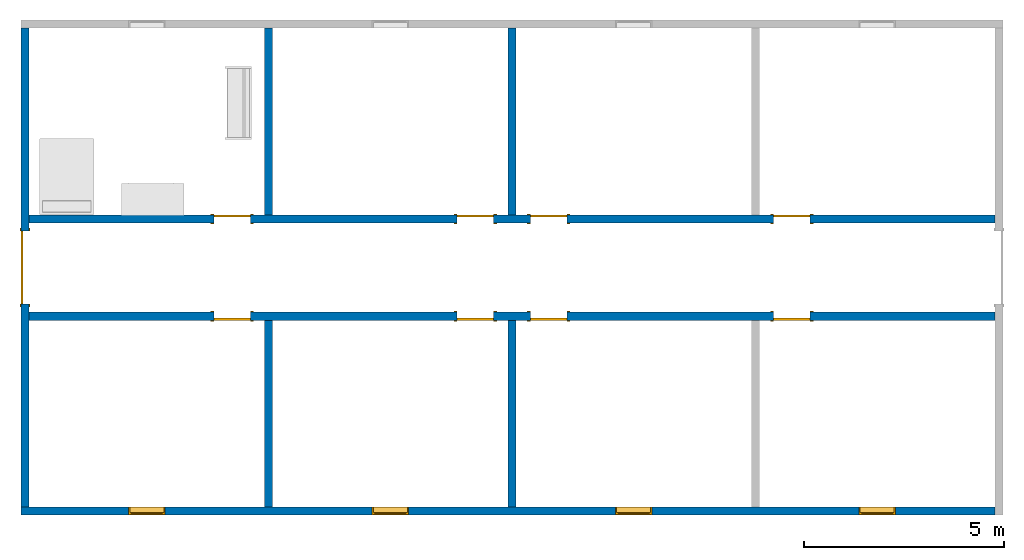
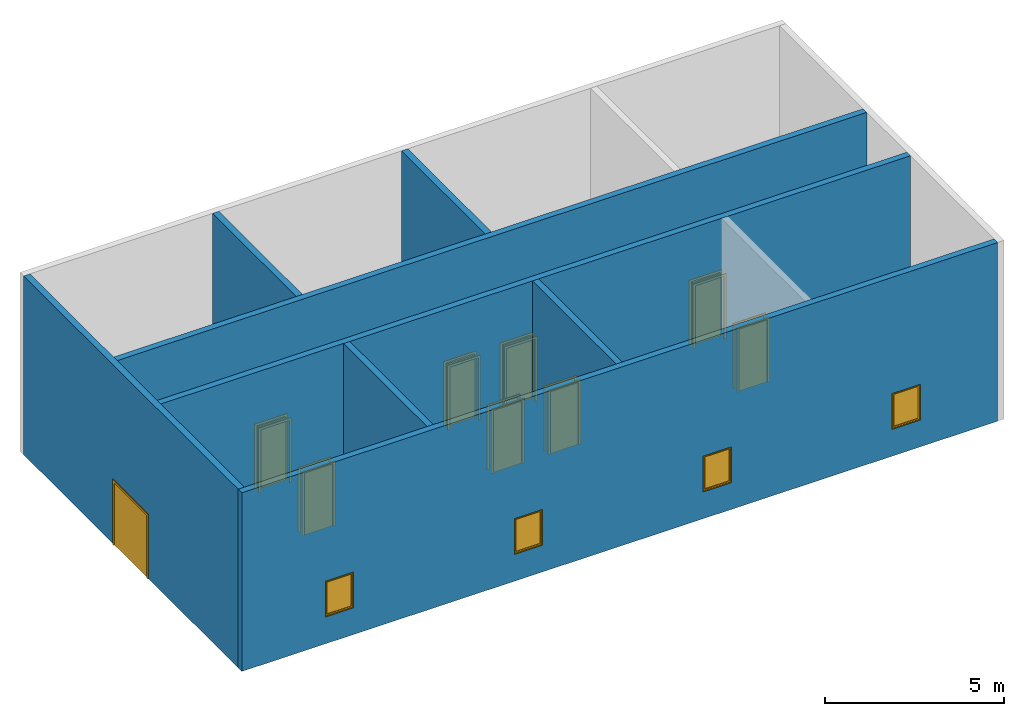
# One storey, part 1 of 4: 9 doors, 8 walls, 4 windows, 13 openings.
"""IFC2X3 building model written with IfcOpenShell, lengths in feet."""

from ifc_helpers import new_model, entity, si_unit, converted_unit, derived_unit, direction, frame, frame_2d, origin, place, context, subcontext, project, spatial, polyline, rectangle, outline, extrude, source, transform, mapped, material, material_list, layer, layer_set, layer_usage, type_object, type_shapes, element, fill, save


model = new_model("IFC2X3")

# Units and contexts
model_context = context("Model", 3, precision=0.0001, world=origin(), true_north=direction((6.123031769111886e-17, 1.0)))
body_context = subcontext(model_context, "Body", "Model", "MODEL_VIEW")
ifc_project = project(units=[converted_unit("LENGTHUNIT", "FOOT", entity("IfcRatioMeasure", 0.3048), si_unit("LENGTHUNIT", "METRE"), dimensions=[1, 0, 0, 0, 0, 0, 0]), converted_unit("AREAUNIT", "SQUARE FOOT", entity("IfcRatioMeasure", 0.09290304), si_unit("AREAUNIT", "SQUARE_METRE"), dimensions=[2, 0, 0, 0, 0, 0, 0]), converted_unit("VOLUMEUNIT", "CUBIC FOOT", entity("IfcRatioMeasure", 0.028316846592000004), si_unit("VOLUMEUNIT", "CUBIC_METRE"), dimensions=[3, 0, 0, 0, 0, 0, 0]), converted_unit("PLANEANGLEUNIT", "DEGREE", entity("IfcRatioMeasure", 0.017453292519943278), si_unit("PLANEANGLEUNIT", "RADIAN"), dimensions=[0, 0, 0, 0, 0, 0, 0]), si_unit("MASSUNIT", "GRAM", prefix="KILO"), derived_unit("MASSDENSITYUNIT", [(si_unit("MASSUNIT", "GRAM", prefix="KILO"), 1), (si_unit("LENGTHUNIT", "METRE"), -3)]), derived_unit("MOMENTOFINERTIAUNIT", [(si_unit("LENGTHUNIT", "METRE"), 4)]), si_unit("TIMEUNIT", "SECOND"), si_unit("FREQUENCYUNIT", "HERTZ"), si_unit("THERMODYNAMICTEMPERATUREUNIT", "DEGREE_CELSIUS"), derived_unit("THERMALTRANSMITTANCEUNIT", [(si_unit("MASSUNIT", "GRAM", prefix="KILO"), 1), (si_unit("THERMODYNAMICTEMPERATUREUNIT", "KELVIN"), -1), (si_unit("TIMEUNIT", "SECOND"), -3)]), derived_unit("VOLUMETRICFLOWRATEUNIT", [(si_unit("LENGTHUNIT", "METRE"), 3), (si_unit("TIMEUNIT", "SECOND"), -1)]), derived_unit("MASSFLOWRATEUNIT", [(si_unit("MASSUNIT", "GRAM", prefix="KILO"), 1), (si_unit("TIMEUNIT", "SECOND"), -1)]), derived_unit("ROTATIONALFREQUENCYUNIT", [(si_unit("TIMEUNIT", "SECOND"), -1)]), si_unit("ELECTRICCURRENTUNIT", "AMPERE"), si_unit("ELECTRICVOLTAGEUNIT", "VOLT"), si_unit("POWERUNIT", "WATT"), si_unit("FORCEUNIT", "NEWTON"), si_unit("ILLUMINANCEUNIT", "LUX"), si_unit("LUMINOUSFLUXUNIT", "LUMEN"), si_unit("LUMINOUSINTENSITYUNIT", "CANDELA"), derived_unit("USERDEFINED", [(si_unit("MASSUNIT", "GRAM", prefix="KILO"), -1), (si_unit("LENGTHUNIT", "METRE"), -2), (si_unit("TIMEUNIT", "SECOND"), 3), (si_unit("LUMINOUSFLUXUNIT", "LUMEN"), 1)]), derived_unit("SOUNDPOWERUNIT", [(si_unit("MASSUNIT", "GRAM", prefix="KILO"), 1), (si_unit("LENGTHUNIT", "METRE"), 2), (si_unit("TIMEUNIT", "SECOND"), -3)]), derived_unit("SOUNDPRESSUREUNIT", [(si_unit("MASSUNIT", "GRAM", prefix="KILO"), 1), (si_unit("LENGTHUNIT", "METRE"), -1), (si_unit("TIMEUNIT", "SECOND"), -2)]), derived_unit("LINEARVELOCITYUNIT", [(si_unit("LENGTHUNIT", "METRE"), 1), (si_unit("TIMEUNIT", "SECOND"), -1)]), si_unit("PRESSUREUNIT", "PASCAL"), derived_unit("USERDEFINED", [(si_unit("LENGTHUNIT", "METRE"), -2), (si_unit("MASSUNIT", "GRAM", prefix="KILO"), 1), (si_unit("TIMEUNIT", "SECOND"), -2)]), derived_unit("LINEARFORCEUNIT", [(si_unit("MASSUNIT", "GRAM", prefix="KILO"), 1), (si_unit("LENGTHUNIT", "METRE"), 1), (si_unit("TIMEUNIT", "SECOND"), -2), (si_unit("LENGTHUNIT", "METRE"), -1)]), derived_unit("PLANARFORCEUNIT", [(si_unit("MASSUNIT", "GRAM", prefix="KILO"), 1), (si_unit("LENGTHUNIT", "METRE"), 1), (si_unit("TIMEUNIT", "SECOND"), -2), (si_unit("LENGTHUNIT", "METRE"), -2)])], contexts=[model_context])

# Site, building, storey
site_placement = place(None, origin())
site = spatial("IfcSite", under=ifc_project, at=site_placement, CompositionType="ELEMENT")
building_placement = place(site_placement, origin())
building = spatial("IfcBuilding", under=site, at=building_placement, CompositionType="ELEMENT")
storey_placement = place(building_placement, origin())
storey = spatial("IfcBuildingStorey", under=building, at=storey_placement, Name="Level 1", CompositionType="ELEMENT", Elevation=0.0)

# Wall, openings, windows
ifc_material_1 = material(Name="Default Wall")
ifc_layer = layer(ifc_material_1, 0.6666666666666666)
ifc_layer_set = layer_set([ifc_layer])
ifc_layer_usage_1 = layer_usage(ifc_layer_set, "AXIS2", "NEGATIVE", 0.3333333333333333)
wall_type = type_object("IfcWallType", PredefinedType="STANDARD", material=ifc_layer_set)
wall_1_placement = place(storey_placement, frame((40.57714681396368, -10.741261883943183, 0.0), z_axis=(0.0, 0.0, 1.0), x_axis=(-1.0, 0.0, 0.0)))
wall_1 = element("IfcWallStandardCase", 1, at=wall_1_placement, inside=storey, type_object=wall_type, material=ifc_layer_usage_1, context=body_context, shape_type="SweptSolid", body=[
    extrude(rectangle(XDim=80.00000000000001, YDim=0.6666666666666661, at=frame_2d((40.000000000000014, -7.216449660063518e-16), x_axis=(-1.0, 0.0))), origin(), (0.0, 0.0, 1.0), 20.0),
])
opening_1_placement = place(wall_1_placement, frame((68.1666666666667, -0.33333333333355597, 3.0)))
opening_1 = element("IfcOpeningElement", 2, at=opening_1_placement, cuts=wall_1, ObjectType="Opening", context=body_context, shape_type="SweptSolid", body=[
    extrude(rectangle(XDim=4.0, YDim=2.9999999999999987, at=frame_2d((2.0, 1.5000000000000007), x_axis=(-1.0, 0.0))), frame((0.0, 0.0, 0.0), z_axis=(0.0, 1.0, 0.0), x_axis=(0.0, 0.0, 1.0)), (0.0, 0.0, 1.0), 0.6666666666666666),
])
opening_2_placement = place(wall_1_placement, frame((48.16666666666669, -0.333333333333492, 3.0)))
opening_2 = element("IfcOpeningElement", 3, at=opening_2_placement, cuts=wall_1, ObjectType="Opening", context=body_context, shape_type="SweptSolid", body=[
    extrude(rectangle(XDim=4.0, YDim=2.9999999999999987, at=frame_2d((2.0, 1.5000000000000007), x_axis=(-1.0, 0.0))), frame((0.0, 0.0, 0.0), z_axis=(0.0, 1.0, 0.0), x_axis=(0.0, 0.0, 1.0)), (0.0, 0.0, 1.0), 0.6666666666666666),
])
opening_3_placement = place(wall_1_placement, frame((28.166666666666742, -0.3333333333334263, 3.0)))
opening_3 = element("IfcOpeningElement", 4, at=opening_3_placement, cuts=wall_1, ObjectType="Opening", context=body_context, shape_type="SweptSolid", body=[
    extrude(rectangle(XDim=4.0, YDim=2.9999999999999987, at=frame_2d((2.0, 1.5000000000000007), x_axis=(-1.0, 0.0))), frame((0.0, 0.0, 0.0), z_axis=(0.0, 1.0, 0.0), x_axis=(0.0, 0.0, 1.0)), (0.0, 0.0, 1.0), 0.6666666666666666),
])
opening_4_placement = place(wall_1_placement, frame((8.166666666666728, -0.33333333333336235, 3.0)))
opening_4 = element("IfcOpeningElement", 5, at=opening_4_placement, cuts=wall_1, ObjectType="Opening", context=body_context, shape_type="SweptSolid", body=[
    extrude(rectangle(XDim=4.0, YDim=2.9999999999999987, at=frame_2d((2.0, 1.5000000000000042), x_axis=(-1.0, 0.0))), frame((0.0, 0.0, 0.0), z_axis=(0.0, 1.0, 0.0), x_axis=(0.0, 0.0, 1.0)), (0.0, 0.0, 1.0), 0.6666666666666666),
])
ifc_material_2 = material(Name="Glass")
ifc_material_3 = material(Name="Sash")
ifc_material_list_1 = material_list([ifc_material_2, ifc_material_3, ifc_material_3, ifc_material_3])
ifc_material_list_2 = material_list([ifc_material_2, ifc_material_3, ifc_material_3, ifc_material_3])
window_style = type_object("IfcWindowStyle", ConstructionType="NOTDEFINED", OperationType="NOTDEFINED", ParameterTakesPrecedence=False, Sizeable=False, material=ifc_material_list_2)
shared_shape_1 = source(origin(), body_context, "Body", "SweptSolid", [
    extrude(rectangle(XDim=2.5833333333333313, YDim=0.04166666666666666, at=frame_2d((0.0, -1.3877787807814457e-17), x_axis=(1.0, 0.0))), frame((1.7500000000000173, 0.53125, 0.2083333333333215)), (0.0, 0.0, 1.0), 3.5833333333333393),
    extrude(outline(polyline([(-1.4374999999999971, -1.9375000000000053), (1.4374999999999971, -1.9375000000000053), (1.4374999999999971, 1.9375000000000053), (-1.4374999999999971, 1.9375000000000053), (-1.4374999999999971, -1.9375000000000053)]), holes=[polyline([(-1.291666666666665, -1.7916666666666696), (-1.291666666666665, 1.7916666666666696), (1.2916666666666663, 1.7916666666666696), (1.2916666666666663, -1.7916666666666696), (-1.291666666666665, -1.7916666666666696)])]), frame((1.750000000000018, 0.6041666666666666, 2.0), z_axis=(0.0, -1.0, 0.0), x_axis=(-1.0, 0.0, 0.0)), (0.0, 0.0, 1.0), 0.14583333333333331),
    extrude(outline(polyline([(-1.499999999999997, -2.0), (1.499999999999997, -2.0), (1.499999999999997, 2.0), (-1.499999999999997, 2.0), (-1.499999999999997, -2.0)]), holes=[polyline([(-1.3958333333333353, -1.8958333333333277), (-1.3958333333333353, 1.8958333333333508), (1.3958333333333293, 1.8958333333333508), (1.3958333333333293, -1.8958333333333277), (-1.3958333333333353, -1.8958333333333277)])]), frame((1.7500000000000149, 0.4583333333333333, 2.0), z_axis=(0.0, -1.0, 0.0), x_axis=(-1.0, 0.0, 0.0)), (0.0, 0.0, 1.0), 0.4583333333333333),
    extrude(outline(polyline([(-2.0, -1.5000000000000002), (2.0, -1.5000000000000002), (2.0, 1.5000000000000002), (-2.0, 1.5000000000000002), (-2.0, -1.5000000000000002)]), holes=[polyline([(-1.9374999999999973, -1.4374999999999953), (-1.9374999999999973, 1.4375000000000016), (1.9375000000000115, 1.4375000000000016), (1.9375000000000115, -1.4374999999999953), (-1.9374999999999973, -1.4374999999999953)])]), frame((1.7500000000000149, 0.6666666666666666, 2.0), z_axis=(0.0, -1.0, 0.0), x_axis=(0.0, 0.0, -1.0)), (0.0, 0.0, 1.0), 0.20833333333333331),
])
type_shapes(window_style, [shared_shape_1])
window_1_placement = place(opening_1_placement, frame((-0.25000000000002487, 0.0, 0.0)))
window_1 = element("IfcWindow", 6, at=window_1_placement, inside=storey, type_object=window_style, material=ifc_material_list_1, OverallHeight=4.0, OverallWidth=3.0, context=body_context, shape_type="MappedRepresentation", body=[
    mapped(shared_shape_1, transform((0.0, 0.0, 0.0), scale=1.0)),
])
fill(opening_1, window_1)
ifc_material_list_3 = material_list([ifc_material_2, ifc_material_3])
window_2_placement = place(opening_2_placement, frame((-0.2500000000000169, 0.0, 0.0)))
window_2 = element("IfcWindow", 7, at=window_2_placement, inside=storey, type_object=window_style, material=ifc_material_list_3, OverallHeight=4.0, OverallWidth=2.999999999999999, context=body_context, shape_type="MappedRepresentation", body=[
    mapped(shared_shape_1, transform((0.0, 0.0, 0.0), scale=1.0)),
])
fill(opening_2, window_2)
ifc_material_list_4 = material_list([ifc_material_2, ifc_material_3])
window_3_placement = place(opening_3_placement, frame((-0.25000000000001776, 0.0, 0.0)))
window_3 = element("IfcWindow", 8, at=window_3_placement, inside=storey, type_object=window_style, material=ifc_material_list_4, OverallHeight=4.0, OverallWidth=2.9999999999999982, context=body_context, shape_type="MappedRepresentation", body=[
    mapped(shared_shape_1, transform((0.0, 0.0, 0.0), scale=1.0)),
])
fill(opening_3, window_3)
ifc_material_list_5 = material_list([ifc_material_2, ifc_material_3])
window_4_placement = place(opening_4_placement, frame((-0.2500000000000142, 0.0, 0.0)))
window_4 = element("IfcWindow", 9, at=window_4_placement, inside=storey, type_object=window_style, material=ifc_material_list_5, OverallHeight=4.0, OverallWidth=3.0000000000000036, context=body_context, shape_type="MappedRepresentation", body=[
    mapped(shared_shape_1, transform((0.0, 0.0, 0.0), scale=1.0)),
])
fill(opening_4, window_4)

# Wall, opening, door
ifc_layer_usage_2 = layer_usage(ifc_layer_set, "AXIS2", "NEGATIVE", 0.3333333333333333)
wall_2_placement = place(storey_placement, frame((-39.089519852703006, -10.407928550609597, 0.0), z_axis=(0.0, 0.0, 1.0), x_axis=(0.0, 1.0, 0.0)))
wall_2 = element("IfcWallStandardCase", 10, at=wall_2_placement, inside=storey, type_object=wall_type, material=ifc_layer_usage_2, context=body_context, shape_type="SweptSolid", body=[
    extrude(rectangle(XDim=39.333333333333336, YDim=0.6666666666666643, at=frame_2d((19.666666666666668, 3.608224830031759e-15), x_axis=(1.0, 0.0))), origin(), (0.0, 0.0, 1.0), 20.0),
])
opening_5_placement = place(wall_2_placement, frame((16.666666666666657, -0.3333333333333563, 0.0)))
opening_5 = element("IfcOpeningElement", 11, at=opening_5_placement, cuts=wall_2, ObjectType="Opening", context=body_context, shape_type="SweptSolid", body=[
    extrude(rectangle(XDim=6.999999999999998, YDim=5.999999999999998, at=frame_2d((3.499999999999999, 2.999999999999999), x_axis=(1.0, 0.0))), frame((0.0, 0.0, 0.0), z_axis=(0.0, 1.0, 0.0), x_axis=(0.0, 0.0, 1.0)), (0.0, 0.0, 1.0), 0.6666666666666666),
])
ifc_material_4 = material(Name="Paint - Sienna")
ifc_material_5 = material(Name="Wood - Birch - Solid Stained Light Low Gloss")
ifc_material_list_6 = material_list([ifc_material_4, ifc_material_5])
ifc_material_list_7 = material_list([ifc_material_4, ifc_material_4, ifc_material_5, ifc_material_5])
door_style_1 = type_object("IfcDoorStyle", ConstructionType="NOTDEFINED", OperationType="DOUBLE_DOOR_SINGLE_SWING_OPPOSITE_LEFT", ParameterTakesPrecedence=False, Sizeable=False, material=ifc_material_list_7)
shared_shape_2 = source(origin(), body_context, "Body", "SweptSolid", [
    extrude(outline(polyline([(-3.437499999999999, 3.0), (3.562499999999999, 3.0), (3.562499999999999, 3.249999999999999), (-3.687499999999999, 3.249999999999999), (-3.687499999999999, -3.249999999999999), (3.562499999999999, -3.249999999999999), (3.562499999999999, -3.0), (-3.437499999999999, -3.0), (-3.437499999999999, 3.0)])), frame((3.0, -0.08333333333334297, 3.562499999999999), z_axis=(0.0, 1.0, 0.0), x_axis=(0.0, 0.0, -1.0)), (0.0, 0.0, 1.0), 0.08333333333333331),
    extrude(outline(polyline([(-3.437499999999999, 3.0), (3.562499999999999, 3.0), (3.562499999999999, 3.25), (-3.687499999999999, 3.25), (-3.687499999999999, -3.25), (3.562499999999999, -3.25), (3.562499999999999, -3.0), (-3.437499999999999, -3.0), (-3.437499999999999, 3.0)])), frame((3.0, 0.666666666666657, 3.562499999999999), z_axis=(0.0, 1.0, 0.0), x_axis=(0.0, 0.0, -1.0)), (0.0, 0.0, 1.0), 0.08333333333333331),
    extrude(rectangle(XDim=0.1666666666666505, YDim=3.0000000000000013, at=frame_2d((-1.3877787807814457e-17, 0.0), x_axis=(1.0, 0.0))), frame((4.5, 0.5833333333333155, 0.0), z_axis=(0.0, 0.0, 1.0), x_axis=(0.0, -1.0, 0.0)), (0.0, 0.0, 1.0), 6.999999999999998),
    extrude(rectangle(XDim=0.16666666666666669, YDim=2.9999999999999947, at=frame_2d((-1.3877787807814457e-17, -2.220446049250313e-16), x_axis=(1.0, 0.0))), frame((1.5000000000000018, 0.5833333333333284, 0.0), z_axis=(0.0, 0.0, 1.0), x_axis=(0.0, -1.0, 0.0)), (0.0, 0.0, 1.0), 7.0),
])
type_shapes(door_style_1, [shared_shape_2])
door_1_placement = place(opening_5_placement, origin())
door_1 = element("IfcDoor", 12, at=door_1_placement, inside=storey, type_object=door_style_1, material=ifc_material_list_6, OverallHeight=6.999999999999998, OverallWidth=5.999999999999998, context=body_context, shape_type="MappedRepresentation", body=[
    mapped(shared_shape_2, transform((0.0, 0.0, 0.0), scale=1.0)),
])
fill(opening_5, door_1)

# Wall, openings, doors
ifc_layer_usage_3 = layer_usage(ifc_layer_set, "AXIS2", "NEGATIVE", 0.3333333333333333)
wall_3_placement = place(storey_placement, frame((-38.75618651936965, 5.258738116057073, 0.0)))
wall_3 = element("IfcWallStandardCase", 13, at=wall_3_placement, inside=storey, type_object=wall_type, material=ifc_layer_usage_3, context=body_context, shape_type="SweptSolid", body=[
    extrude(rectangle(XDim=79.33333333333333, YDim=0.666666666666667, at=frame_2d((39.666666666666664, -6.38378239159465e-16), x_axis=(1.0, 0.0))), origin(), (0.0, 0.0, 1.0), 20.0),
])
opening_6_placement = place(wall_3_placement, frame((44.16666666666665, 0.3333333333331946, 0.0)))
opening_6 = element("IfcOpeningElement", 14, at=opening_6_placement, cuts=wall_3, ObjectType="Opening", context=body_context, shape_type="SweptSolid", body=[
    extrude(rectangle(XDim=2.999999999999999, YDim=6.999999999999999, at=frame_2d((3.4999999999999996, 1.5000000000000002), x_axis=(0.0, 1.0))), frame((0.0, 0.0, 0.0), z_axis=(0.0, -1.0, 0.0), x_axis=(0.0, 0.0, 1.0)), (0.0, 0.0, 1.0), 0.6666666666666666),
])
opening_7_placement = place(wall_3_placement, frame((64.16666666666657, 0.3333333333331288, 0.0)))
opening_7 = element("IfcOpeningElement", 15, at=opening_7_placement, cuts=wall_3, ObjectType="Opening", context=body_context, shape_type="SweptSolid", body=[
    extrude(rectangle(XDim=2.999999999999999, YDim=6.999999999999999, at=frame_2d((3.4999999999999996, 1.5000000000000002), x_axis=(0.0, 1.0))), frame((0.0, 0.0, 0.0), z_axis=(0.0, -1.0, 0.0), x_axis=(0.0, 0.0, 1.0)), (0.0, 0.0, 1.0), 0.6666666666666666),
])
opening_8_placement = place(wall_3_placement, frame((38.16666666666665, 0.333333333333217, 0.0)))
opening_8 = element("IfcOpeningElement", 16, at=opening_8_placement, cuts=wall_3, ObjectType="Opening", context=body_context, shape_type="SweptSolid", body=[
    extrude(rectangle(XDim=2.999999999999999, YDim=6.999999999999999, at=frame_2d((3.4999999999999996, 1.4999999999999998), x_axis=(0.0, -1.0))), frame((0.0, 0.0, 0.0), z_axis=(0.0, -1.0, 0.0), x_axis=(0.0, 0.0, 1.0)), (0.0, 0.0, 1.0), 0.6666666666666666),
])
opening_9_placement = place(wall_3_placement, frame((18.166666666666664, 0.33333333333328274, 0.0)))
opening_9 = element("IfcOpeningElement", 17, at=opening_9_placement, cuts=wall_3, ObjectType="Opening", context=body_context, shape_type="SweptSolid", body=[
    extrude(rectangle(XDim=2.999999999999999, YDim=6.999999999999999, at=frame_2d((3.4999999999999996, 1.4999999999999998), x_axis=(0.0, -1.0))), frame((0.0, 0.0, 0.0), z_axis=(0.0, -1.0, 0.0), x_axis=(0.0, 0.0, 1.0)), (0.0, 0.0, 1.0), 0.6666666666666666),
])
ifc_material_6 = material(Name="Door - Frame")
ifc_material_7 = material(Name="Door - Panel")
ifc_material_list_8 = material_list([ifc_material_6, ifc_material_7])
ifc_material_list_9 = material_list([ifc_material_6, ifc_material_6, ifc_material_7])
door_style_2 = type_object("IfcDoorStyle", ConstructionType="NOTDEFINED", OperationType="SINGLE_SWING_RIGHT", ParameterTakesPrecedence=False, Sizeable=False, material=ifc_material_list_9)
shared_shape_3 = source(origin(), body_context, "Body", "SweptSolid", [
    extrude(outline(polyline([(-1.7500000000000002, -3.687499999999997), (1.7499999999999993, -3.687499999999997), (1.7499999999999993, 3.5625000000000013), (1.4999999999999993, 3.5625000000000013), (1.4999999999999993, -3.4375000000000067), (-1.4999999999999984, -3.4375000000000067), (-1.4999999999999984, 3.5625000000000013), (-1.7500000000000002, 3.5625000000000013), (-1.7500000000000002, -3.687499999999997)])), frame((1.5000000000000016, 0.6666666666666639, 3.5625000000000013), z_axis=(0.0, 1.0, 0.0), x_axis=(1.0, 0.0, 0.0)), (0.0, 0.0, 1.0), 0.08333333333333331),
    extrude(outline(polyline([(-3.687499999999999, -1.749999999999991), (3.562499999999999, -1.749999999999991), (3.562499999999999, -1.5000000000000246), (-3.437499999999999, -1.5000000000000246), (-3.437499999999999, 1.5000000000000064), (3.562499999999999, 1.5000000000000064), (3.562499999999999, 1.7500000000000087), (-3.687499999999999, 1.7500000000000087), (-3.687499999999999, -1.749999999999991)])), frame((1.5000000000000102, -0.08333333333333615, 3.562499999999999), z_axis=(0.0, 1.0, 0.0), x_axis=(0.0, 0.0, -1.0)), (0.0, 0.0, 1.0), 0.08333333333333331),
    extrude(rectangle(XDim=0.16666666666666666, YDim=2.9999999999999996, at=frame_2d((-1.3877787807814457e-17, 0.0), x_axis=(1.0, 0.0))), frame((1.5000000000000009, 0.5833333333333306, 0.0), z_axis=(0.0, 0.0, 1.0), x_axis=(0.0, 1.0, 0.0)), (0.0, 0.0, 1.0), 6.999999999999998),
])
type_shapes(door_style_2, [shared_shape_3])
door_2_placement = place(opening_6_placement, frame((0.0, 0.0, 0.0), z_axis=(0.0, 0.0, 1.0), x_axis=(-1.0, 0.0, 0.0)))
door_2 = element("IfcDoor", 18, at=door_2_placement, inside=storey, type_object=door_style_2, material=ifc_material_list_8, OverallHeight=6.999999999999999, OverallWidth=3.000000000000001, context=body_context, shape_type="MappedRepresentation", body=[
    mapped(shared_shape_3, transform((0.0, 0.0, 0.0), scale=1.0)),
])
fill(opening_6, door_2)
ifc_material_list_10 = material_list([ifc_material_6, ifc_material_7])
door_3_placement = place(opening_7_placement, frame((0.0, 0.0, 0.0), z_axis=(0.0, 0.0, 1.0), x_axis=(-1.0, 0.0, 0.0)))
door_3 = element("IfcDoor", 19, at=door_3_placement, inside=storey, type_object=door_style_2, material=ifc_material_list_10, OverallHeight=6.999999999999999, OverallWidth=3.0, context=body_context, shape_type="MappedRepresentation", body=[
    mapped(shared_shape_3, transform((0.0, 0.0, 0.0), scale=1.0)),
])
fill(opening_7, door_3)
ifc_material_list_11 = material_list([ifc_material_6, ifc_material_7])
ifc_material_list_12 = material_list([ifc_material_6, ifc_material_6, ifc_material_7])
door_style_3 = type_object("IfcDoorStyle", ConstructionType="NOTDEFINED", OperationType="SINGLE_SWING_LEFT", ParameterTakesPrecedence=False, Sizeable=False, material=ifc_material_list_12)
shared_shape_4 = source(origin(), body_context, "Body", "SweptSolid", [
    extrude(outline(polyline([(-1.7500000000000002, -3.687499999999997), (1.7499999999999993, -3.687499999999997), (1.7499999999999993, 3.5625000000000013), (1.4999999999999993, 3.5625000000000013), (1.4999999999999993, -3.4375000000000067), (-1.4999999999999984, -3.4375000000000067), (-1.4999999999999984, 3.5625000000000013), (-1.7500000000000002, 3.5625000000000013), (-1.7500000000000002, -3.687499999999997)])), frame((1.5000000000000004, 0.7499999999999793, 3.5625000000000013), z_axis=(0.0, -1.0, 0.0), x_axis=(-1.0, 0.0, 0.0)), (0.0, 0.0, 1.0), 0.08333333333333331),
    extrude(outline(polyline([(-3.687499999999999, -1.7499999999999907), (3.562499999999999, -1.7499999999999907), (3.562499999999999, -1.5000000000000244), (-3.437499999999999, -1.5000000000000244), (-3.437499999999999, 1.5000000000000067), (3.562499999999999, 1.5000000000000067), (3.562499999999999, 1.7500000000000089), (-3.687499999999999, 1.7500000000000089), (-3.687499999999999, -1.7499999999999907)])), frame((1.4999999999999916, 0.0, 3.562499999999999), z_axis=(0.0, -1.0, 0.0), x_axis=(0.0, 0.0, -1.0)), (0.0, 0.0, 1.0), 0.08333333333333331),
    extrude(rectangle(XDim=2.9999999999999996, YDim=0.16666666666666666, at=frame_2d((0.0, -1.3877787807814457e-17), x_axis=(1.0, 0.0))), frame((1.5000000000000009, 0.5833333333333126, 0.0)), (0.0, 0.0, 1.0), 6.999999999999998),
])
type_shapes(door_style_3, [shared_shape_4])
door_4_placement = place(opening_8_placement, frame((0.0, 0.0, 0.0), z_axis=(0.0, 0.0, 1.0), x_axis=(-1.0, 0.0, 0.0)))
door_4 = element("IfcDoor", 20, at=door_4_placement, inside=storey, type_object=door_style_3, material=ifc_material_list_11, OverallHeight=6.999999999999999, OverallWidth=3.0, context=body_context, shape_type="MappedRepresentation", body=[
    mapped(shared_shape_4, transform((0.0, 0.0, 0.0), scale=1.0)),
])
fill(opening_8, door_4)
ifc_material_list_13 = material_list([ifc_material_6, ifc_material_7])
door_5_placement = place(opening_9_placement, frame((0.0, 0.0, 0.0), z_axis=(0.0, 0.0, 1.0), x_axis=(-1.0, 0.0, 0.0)))
door_5 = element("IfcDoor", 21, at=door_5_placement, inside=storey, type_object=door_style_3, material=ifc_material_list_13, OverallHeight=6.999999999999999, OverallWidth=3.0, context=body_context, shape_type="MappedRepresentation", body=[
    mapped(shared_shape_4, transform((0.0, 0.0, 0.0), scale=1.0)),
])
fill(opening_9, door_5)

ifc_layer_usage_4 = layer_usage(ifc_layer_set, "AXIS2", "NEGATIVE", 0.3333333333333333)
wall_4_placement = place(storey_placement, frame((-38.75618651936964, 13.258738116057073, 0.0)))
wall_4 = element("IfcWallStandardCase", 22, at=wall_4_placement, inside=storey, type_object=wall_type, material=ifc_layer_usage_4, context=body_context, shape_type="SweptSolid", body=[
    extrude(rectangle(XDim=79.3333333333333, YDim=0.6666666666666661, at=frame_2d((39.666666666666664, 1.582067810090848e-15), x_axis=(1.0, 0.0))), origin(), (0.0, 0.0, 1.0), 20.0),
])
opening_10_placement = place(wall_4_placement, frame((15.166666666666668, -0.33333333333338483, 0.0)))
opening_10 = element("IfcOpeningElement", 23, at=opening_10_placement, cuts=wall_4, ObjectType="Opening", context=body_context, shape_type="SweptSolid", body=[
    extrude(rectangle(XDim=2.999999999999999, YDim=6.999999999999999, at=frame_2d((3.4999999999999996, 1.4999999999999984), x_axis=(0.0, 1.0))), frame((0.0, 0.0, 0.0), z_axis=(0.0, 1.0, 0.0), x_axis=(0.0, 0.0, 1.0)), (0.0, 0.0, 1.0), 0.6666666666666666),
])
opening_11_placement = place(wall_4_placement, frame((35.16666666666658, -0.3333333333334506, 0.0)))
opening_11 = element("IfcOpeningElement", 24, at=opening_11_placement, cuts=wall_4, ObjectType="Opening", context=body_context, shape_type="SweptSolid", body=[
    extrude(rectangle(XDim=2.999999999999999, YDim=6.999999999999999, at=frame_2d((3.4999999999999996, 1.5000000000000002), x_axis=(0.0, 1.0))), frame((0.0, 0.0, 0.0), z_axis=(0.0, 1.0, 0.0), x_axis=(0.0, 0.0, 1.0)), (0.0, 0.0, 1.0), 0.6666666666666666),
])
opening_12_placement = place(wall_4_placement, frame((41.16666666666658, -0.3333333333334737, 0.0)))
opening_12 = element("IfcOpeningElement", 25, at=opening_12_placement, cuts=wall_4, ObjectType="Opening", context=body_context, shape_type="SweptSolid", body=[
    extrude(rectangle(XDim=2.999999999999999, YDim=6.999999999999999, at=frame_2d((3.4999999999999996, 1.4999999999999998), x_axis=(0.0, -1.0))), frame((0.0, 0.0, 0.0), z_axis=(0.0, 1.0, 0.0), x_axis=(0.0, 0.0, 1.0)), (0.0, 0.0, 1.0), 0.6666666666666666),
])
opening_13_placement = place(wall_4_placement, frame((61.16666666666657, -0.33333333333353937, 0.0)))
opening_13 = element("IfcOpeningElement", 26, at=opening_13_placement, cuts=wall_4, ObjectType="Opening", context=body_context, shape_type="SweptSolid", body=[
    extrude(rectangle(XDim=2.999999999999999, YDim=6.999999999999999, at=frame_2d((3.4999999999999996, 1.5000000000000033), x_axis=(0.0, -1.0))), frame((0.0, 0.0, 0.0), z_axis=(0.0, 1.0, 0.0), x_axis=(0.0, 0.0, 1.0)), (0.0, 0.0, 1.0), 0.6666666666666666),
])
ifc_material_list_14 = material_list([ifc_material_6, ifc_material_6, ifc_material_7])
door_6_placement = place(opening_10_placement, origin())
door_6 = element("IfcDoor", 27, at=door_6_placement, inside=storey, type_object=door_style_2, material=ifc_material_list_14, OverallHeight=6.999999999999999, OverallWidth=3.0, context=body_context, shape_type="MappedRepresentation", body=[
    mapped(shared_shape_3, transform((0.0, 0.0, 0.0), scale=1.0)),
])
fill(opening_10, door_6)
ifc_material_list_15 = material_list([ifc_material_6, ifc_material_7])
door_7_placement = place(opening_11_placement, origin())
door_7 = element("IfcDoor", 28, at=door_7_placement, inside=storey, type_object=door_style_2, material=ifc_material_list_15, OverallHeight=6.999999999999999, OverallWidth=3.0, context=body_context, shape_type="MappedRepresentation", body=[
    mapped(shared_shape_3, transform((0.0, 0.0, 0.0), scale=1.0)),
])
fill(opening_11, door_7)
ifc_material_list_16 = material_list([ifc_material_6, ifc_material_6, ifc_material_7])
door_8_placement = place(opening_12_placement, origin())
door_8 = element("IfcDoor", 29, at=door_8_placement, inside=storey, type_object=door_style_3, material=ifc_material_list_16, OverallHeight=6.999999999999999, OverallWidth=3.0000000000000004, context=body_context, shape_type="MappedRepresentation", body=[
    mapped(shared_shape_4, transform((0.0, 0.0, 0.0), scale=1.0)),
])
fill(opening_12, door_8)
ifc_material_list_17 = material_list([ifc_material_6, ifc_material_7])
door_9_placement = place(opening_13_placement, origin())
door_9 = element("IfcDoor", 30, at=door_9_placement, inside=storey, type_object=door_style_3, material=ifc_material_list_17, OverallHeight=6.999999999999999, OverallWidth=3.0, context=body_context, shape_type="MappedRepresentation", body=[
    mapped(shared_shape_4, transform((0.0, 0.0, 0.0), scale=1.0)),
])
fill(opening_13, door_9)

# Walls
ifc_layer_usage_5 = layer_usage(ifc_layer_set, "AXIS2", "NEGATIVE", 0.3333333333333333)
wall_5_placement = place(storey_placement, frame((-19.08951985270295, 28.925404782723675, 0.0), z_axis=(0.0, 0.0, 1.0), x_axis=(0.0, -1.0, 0.0)))
element("IfcWallStandardCase", 31, at=wall_5_placement, inside=storey, type_object=wall_type, material=ifc_layer_usage_5, context=body_context, shape_type="SweptSolid", body=[
    extrude(rectangle(XDim=15.333333333333332, YDim=0.6666666666666643, at=frame_2d((7.666666666666666, -5.273559366969494e-16), x_axis=(-1.0, 0.0))), origin(), (0.0, 0.0, 1.0), 20.0),
])
ifc_layer_usage_6 = layer_usage(ifc_layer_set, "AXIS2", "NEGATIVE", 0.3333333333333333)
wall_6_placement = place(storey_placement, frame((0.910480147296965, 28.92540478272361, 0.0), z_axis=(0.0, 0.0, 1.0), x_axis=(0.0, -1.0, 0.0)))
element("IfcWallStandardCase", 32, at=wall_6_placement, inside=storey, type_object=wall_type, material=ifc_layer_usage_6, context=body_context, shape_type="SweptSolid", body=[
    extrude(rectangle(XDim=15.333333333333334, YDim=0.6666666666666666, at=frame_2d((7.666666666666667, -5.551115123125783e-17), x_axis=(-1.0, 0.0))), origin(), (0.0, 0.0, 1.0), 20.0),
])
ifc_layer_usage_7 = layer_usage(ifc_layer_set, "AXIS2", "NEGATIVE", 0.3333333333333333)
wall_7_placement = place(storey_placement, frame((-19.089519852702985, 4.9254047827236755, 0.0), z_axis=(0.0, 0.0, 1.0), x_axis=(0.0, -1.0, 0.0)))
element("IfcWallStandardCase", 33, at=wall_7_placement, inside=storey, type_object=wall_type, material=ifc_layer_usage_7, context=body_context, shape_type="SweptSolid", body=[
    extrude(rectangle(XDim=15.333333333333336, YDim=0.6666666666666643, at=frame_2d((7.666666666666668, -5.273559366969494e-16), x_axis=(-1.0, 0.0))), origin(), (0.0, 0.0, 1.0), 20.0),
])
ifc_layer_usage_8 = layer_usage(ifc_layer_set, "AXIS2", "NEGATIVE", 0.3333333333333333)
wall_8_placement = place(storey_placement, frame((0.9104801472970004, 4.925404782723612, 0.0), z_axis=(0.0, 0.0, 1.0), x_axis=(0.0, -1.0, 0.0)))
element("IfcWallStandardCase", 34, at=wall_8_placement, inside=storey, type_object=wall_type, material=ifc_layer_usage_8, context=body_context, shape_type="SweptSolid", body=[
    extrude(rectangle(XDim=15.333333333333336, YDim=0.6666666666666665, at=frame_2d((7.666666666666668, 2.7755575615628914e-17), x_axis=(-1.0, 0.0))), origin(), (0.0, 0.0, 1.0), 20.0),
])

save(model, "model.ifc")
